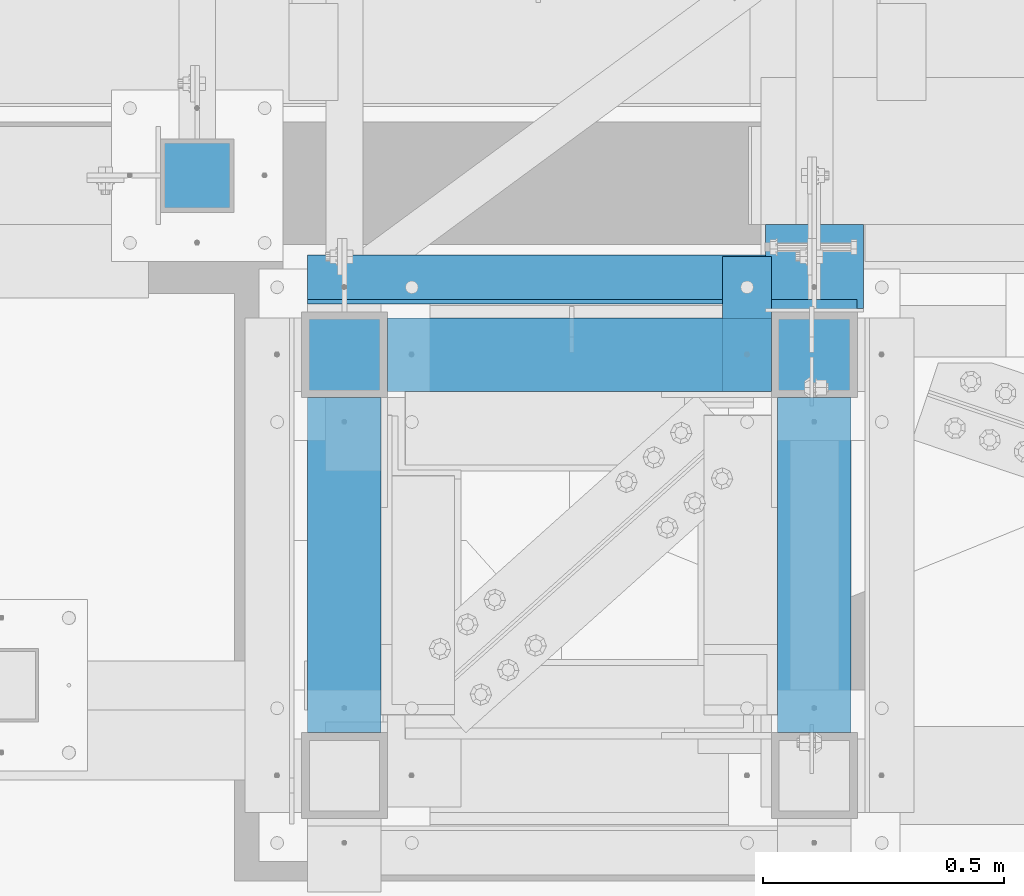
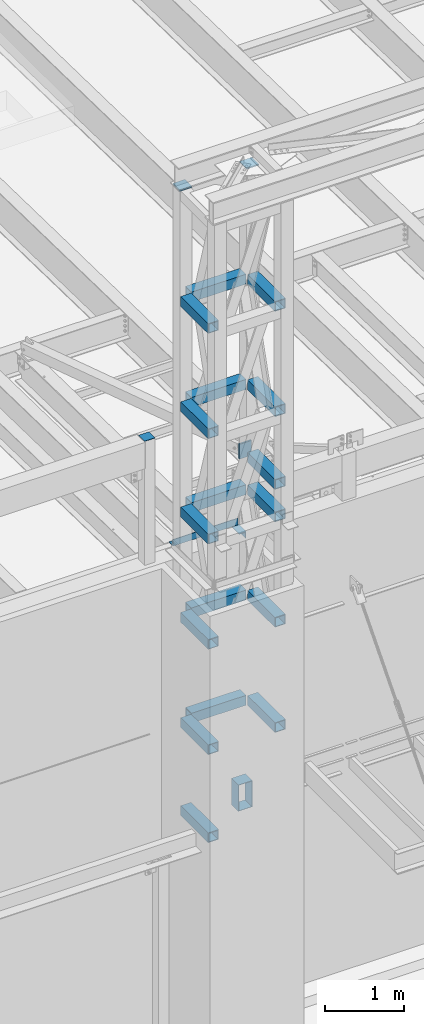
# One storey, part 1200 of 1763: 24 beams, 2 elements without a shape of their own.
"""IFC2X3 building model written with IfcOpenShell, lengths in millimetres."""

from ifc_helpers import new_model, si_unit, frame, origin_with_axes, place, context, subcontext, project, spatial, faceted_brep, material, type_object, element, aggregate, save


model = new_model("IFC2X3")

# Units and contexts
model_context = context("Model", 3, precision=1e-05, world=origin_with_axes())
body_context = subcontext(model_context, "Body", "Model", "MODEL_VIEW")
ifc_project = project(units=[si_unit("LENGTHUNIT", "METRE", prefix="MILLI"), si_unit("AREAUNIT", "SQUARE_METRE"), si_unit("VOLUMEUNIT", "CUBIC_METRE"), si_unit("MASSUNIT", "GRAM", prefix="KILO"), si_unit("TIMEUNIT", "SECOND"), si_unit("PLANEANGLEUNIT", "RADIAN"), si_unit("SOLIDANGLEUNIT", "STERADIAN"), si_unit("THERMODYNAMICTEMPERATUREUNIT", "DEGREE_CELSIUS"), si_unit("LUMINOUSINTENSITYUNIT", "LUMEN")], contexts=[model_context])

# Site, building, storey
site_placement = place(None, origin_with_axes())
site = spatial("IfcSite", under=ifc_project, at=site_placement, CompositionType="ELEMENT")
building_placement = place(site_placement, origin_with_axes())
building = spatial("IfcBuilding", under=site, at=building_placement, Name="Undefined", CompositionType="ELEMENT")
storey_placement = place(building_placement, origin_with_axes())
storey = spatial("IfcBuildingStorey", under=building, at=storey_placement, Name="Undefined", CompositionType="ELEMENT", Elevation=0.0)

# Assembly, beams
assembly_1_placement = place(storey_placement, origin_with_axes())
assembly_1 = element("IfcElementAssembly", 1, at=assembly_1_placement, inside=storey, Name="FRAME", AssemblyPlace="NOTDEFINED", PredefinedType="RIGID_FRAME")
ifc_material_1 = material()
beam_type_1 = type_object("IfcBeamType", Name="HSS6X6X3/8", PredefinedType="NOTDEFINED")
beam_1_placement = place(assembly_1_placement, frame((-63210.5025951483, -15452.7272155183, 14001.7707184703), z_axis=(0.0, 0.0, 1.0), x_axis=(0.0, 1.0, 0.0)))
beam_1 = element("IfcBeam", 2, at=beam_1_placement, type_object=beam_type_1, material=ifc_material_1, Name="BEAM", ObjectType="HSS6X6X3/8", context=body_context, shape_type="Brep", body=[
    faceted_brep([(88.8999008650717, 66.6749999997191, -66.6749999999993), (88.8999007322054, -66.6750000002794, -66.6749999999993), (784.224900732206, -66.6750000025058, -66.6749999999993), (784.224900865072, 66.6749999974927, -66.6749999999993), (88.8999007322054, -66.6750000002794, 66.6749999999993), (784.224900732206, -66.6750000025058, 66.6749999999993), (88.8999008650717, 66.6749999997191, 66.6749999999993), (784.224900865072, 66.6749999974927, 66.6749999999993), (88.8999008745614, 76.1999999997206, -76.2000000000007), (88.8999008745614, 76.1999999997206, 76.2000000000007), (784.224900874562, 76.1999999974942, 76.2000000000007), (784.224900874562, 76.1999999974942, -76.2000000000007), (88.8999007227158, -76.2000000002809, 76.2000000000007), (784.224900722716, -76.2000000025073, 76.2000000000007), (88.8999007227158, -76.2000000002809, -76.2000000000007), (784.224900722716, -76.2000000025073, -76.2000000000007)], [[[0, 1, 2, 3]], [[1, 4, 5, 2]], [[4, 6, 7, 5]], [[6, 0, 3, 7]], [[8, 9, 10, 11]], [[9, 12, 13, 10]], [[12, 14, 15, 13]], [[14, 8, 11, 15]], [[13, 15, 11, 10], [5, 7, 3, 2]], [[14, 12, 9, 8], [6, 4, 1, 0]]]),
])
beam_2_placement = place(assembly_1_placement, frame((-64185.2275957006, -14579.6023151462, 10248.70156), z_axis=(0.0, 0.0, 1.0), x_axis=(0.99999999999718, 2.37500000002911e-06, 0.0)))
beam_2 = element("IfcBeam", 3, at=beam_2_placement, type_object=beam_type_1, material=ifc_material_1, Name="BEAM", ObjectType="HSS6X6X3/8", context=body_context, shape_type="Brep", body=[
    faceted_brep([(88.8999999999996, 66.6750000000029, -66.6749999999993), (88.8996463353687, -66.6749999999556, -66.6749999999993), (885.824841654605, -66.6750000000393, -66.6749999999993), (885.825158360378, 66.6749999998519, -66.6749999999993), (88.8996463353687, -66.6749999999556, 66.6749999999993), (885.824841654605, -66.6750000000393, 66.6749999999993), (88.8999999999996, 66.6750000000029, 66.6749999999993), (885.825158360378, 66.6749999998519, 66.6749999999993), (88.8999999999996, 76.1999999999971, -76.2000000000007), (88.8999999999996, 76.1999999999971, 76.2000000000007), (885.825180982218, 76.1999999998425, 76.2000000000007), (885.825180982218, 76.1999999998425, -76.2000000000007), (88.8996237135289, -76.1999999999498, 76.2000000000007), (885.824819032772, -76.2000000000335, 76.2000000000007), (88.8996237135289, -76.1999999999498, -76.2000000000007), (885.824819032772, -76.2000000000335, -76.2000000000007)], [[[0, 1, 2, 3]], [[1, 4, 5, 2]], [[4, 6, 7, 5]], [[6, 0, 3, 7]], [[8, 9, 10, 11]], [[9, 12, 13, 10]], [[12, 14, 15, 13]], [[14, 8, 11, 15]], [[13, 15, 11, 10], [5, 7, 3, 2]], [[14, 12, 9, 8], [6, 4, 1, 0]]]),
])
beam_3_placement = place(assembly_1_placement, frame((-63210.5025951483, -15452.7272159449, 10248.70156), z_axis=(0.0, 0.0, 1.0), x_axis=(0.0, 1.0, 0.0)))
beam_3 = element("IfcBeam", 4, at=beam_3_placement, type_object=beam_type_1, material=ifc_material_1, Name="BEAM", ObjectType="HSS6X6X3/8", context=body_context, shape_type="Brep", body=[
    faceted_brep([(88.8999008650717, 66.6749999997191, -66.6749999999993), (88.8999007322054, -66.6750000002794, -66.6749999999993), (784.224900732206, -66.6750000025058, -66.6749999999993), (784.224900865072, 66.6749999974927, -66.6749999999993), (88.8999007322054, -66.6750000002794, 66.6749999999993), (784.224900732206, -66.6750000025058, 66.6749999999993), (88.8999008650717, 66.6749999997191, 66.6749999999993), (784.224900865072, 66.6749999974927, 66.6749999999993), (88.8999008745614, 76.1999999997206, -76.2000000000007), (88.8999008745614, 76.1999999997206, 76.2000000000007), (784.224900874562, 76.1999999974942, 76.2000000000007), (784.224900874562, 76.1999999974942, -76.2000000000007), (88.8999007227158, -76.2000000002809, 76.2000000000007), (784.224900722716, -76.2000000025073, 76.2000000000007), (88.8999007227158, -76.2000000002809, -76.2000000000007), (784.224900722716, -76.2000000025073, -76.2000000000007)], [[[0, 1, 2, 3]], [[1, 4, 5, 2]], [[4, 6, 7, 5]], [[6, 0, 3, 7]], [[8, 9, 10, 11]], [[9, 12, 13, 10]], [[12, 14, 15, 13]], [[14, 8, 11, 15]], [[13, 15, 11, 10], [5, 7, 3, 2]], [[14, 12, 9, 8], [6, 4, 1, 0]]]),
])
beam_4_placement = place(assembly_1_placement, frame((-64185.2275951483, -15452.7272100983, 10248.70156), z_axis=(0.0, 0.0, 1.0), x_axis=(0.0, 1.0, 0.0)))
beam_4 = element("IfcBeam", 5, at=beam_4_placement, type_object=beam_type_1, material=ifc_material_1, Name="BEAM", ObjectType="HSS6X6X3/8", context=body_context, shape_type="Brep", body=[
    faceted_brep([(88.8999008650717, 66.6749999997191, -66.6749999999993), (88.8999007322054, -66.6750000002794, -66.6749999999993), (784.224900732206, -66.6750000025058, -66.6749999999993), (784.224900865072, 66.6749999974927, -66.6749999999993), (88.8999007322054, -66.6750000002794, 66.6749999999993), (784.224900732206, -66.6750000025058, 66.6749999999993), (88.8999008650717, 66.6749999997191, 66.6749999999993), (784.224900865072, 66.6749999974927, 66.6749999999993), (88.8999008745614, 76.1999999997206, -76.2000000000007), (88.8999008745614, 76.1999999997206, 76.2000000000007), (784.224900874562, 76.1999999974942, 76.2000000000007), (784.224900874562, 76.1999999974942, -76.2000000000007), (88.8999007227158, -76.2000000002809, 76.2000000000007), (784.224900722716, -76.2000000025073, 76.2000000000007), (88.8999007227158, -76.2000000002809, -76.2000000000007), (784.224900722716, -76.2000000025073, -76.2000000000007)], [[[0, 1, 2, 3]], [[1, 4, 5, 2]], [[4, 6, 7, 5]], [[6, 0, 3, 7]], [[8, 9, 10, 11]], [[9, 12, 13, 10]], [[12, 14, 15, 13]], [[14, 8, 11, 15]], [[13, 15, 11, 10], [5, 7, 3, 2]], [[14, 12, 9, 8], [6, 4, 1, 0]]]),
])
beam_5_placement = place(assembly_1_placement, frame((-64185.2275957006, -14579.6023151462, 11873.706248), z_axis=(0.0, 0.0, 1.0), x_axis=(0.99999999999718, 2.37500000002911e-06, 0.0)))
beam_5 = element("IfcBeam", 6, at=beam_5_placement, type_object=beam_type_1, material=ifc_material_1, Name="BEAM", ObjectType="HSS6X6X3/8", context=body_context, shape_type="Brep", body=[
    faceted_brep([(88.8999999999996, 66.6750000000029, -66.6749999999993), (88.8996463353687, -66.6749999999556, -66.6749999999993), (885.824841654605, -66.6750000000393, -66.6749999999993), (885.825158360378, 66.6749999998519, -66.6749999999993), (88.8996463353687, -66.6749999999556, 66.6749999999993), (885.824841654605, -66.6750000000393, 66.6749999999993), (88.8999999999996, 66.6750000000029, 66.6749999999993), (885.825158360378, 66.6749999998519, 66.6749999999993), (88.8999999999996, 76.1999999999971, -76.2000000000007), (88.8999999999996, 76.1999999999971, 76.2000000000007), (885.825180982218, 76.1999999998425, 76.2000000000007), (885.825180982218, 76.1999999998425, -76.2000000000007), (88.8996237135289, -76.1999999999498, 76.2000000000007), (885.824819032772, -76.2000000000335, 76.2000000000007), (88.8996237135289, -76.1999999999498, -76.2000000000007), (885.824819032772, -76.2000000000335, -76.2000000000007)], [[[0, 1, 2, 3]], [[1, 4, 5, 2]], [[4, 6, 7, 5]], [[6, 0, 3, 7]], [[8, 9, 10, 11]], [[9, 12, 13, 10]], [[12, 14, 15, 13]], [[14, 8, 11, 15]], [[13, 15, 11, 10], [5, 7, 3, 2]], [[14, 12, 9, 8], [6, 4, 1, 0]]]),
])
beam_6_placement = place(assembly_1_placement, frame((-63210.5025951483, -15452.7272159449, 11873.706248), z_axis=(0.0, 0.0, 1.0), x_axis=(0.0, 1.0, 0.0)))
beam_6 = element("IfcBeam", 7, at=beam_6_placement, type_object=beam_type_1, material=ifc_material_1, Name="BEAM", ObjectType="HSS6X6X3/8", context=body_context, shape_type="Brep", body=[
    faceted_brep([(88.8999008650717, 66.6749999997191, -66.6749999999993), (88.8999007322054, -66.6750000002794, -66.6749999999993), (784.224900732206, -66.6750000025058, -66.6749999999993), (784.224900865072, 66.6749999974927, -66.6749999999993), (88.8999007322054, -66.6750000002794, 66.6749999999993), (784.224900732206, -66.6750000025058, 66.6749999999993), (88.8999008650717, 66.6749999997191, 66.6749999999993), (784.224900865072, 66.6749999974927, 66.6749999999993), (88.8999008745614, 76.1999999997206, -76.2000000000007), (88.8999008745614, 76.1999999997206, 76.2000000000007), (784.224900874562, 76.1999999974942, 76.2000000000007), (784.224900874562, 76.1999999974942, -76.2000000000007), (88.8999007227158, -76.2000000002809, 76.2000000000007), (784.224900722716, -76.2000000025073, 76.2000000000007), (88.8999007227158, -76.2000000002809, -76.2000000000007), (784.224900722716, -76.2000000025073, -76.2000000000007)], [[[0, 1, 2, 3]], [[1, 4, 5, 2]], [[4, 6, 7, 5]], [[6, 0, 3, 7]], [[8, 9, 10, 11]], [[9, 12, 13, 10]], [[12, 14, 15, 13]], [[14, 8, 11, 15]], [[13, 15, 11, 10], [5, 7, 3, 2]], [[14, 12, 9, 8], [6, 4, 1, 0]]]),
])
beam_7_placement = place(assembly_1_placement, frame((-64185.2275951483, -15452.7272100983, 11873.706248), z_axis=(0.0, 0.0, 1.0), x_axis=(0.0, 1.0, 0.0)))
beam_7 = element("IfcBeam", 8, at=beam_7_placement, type_object=beam_type_1, material=ifc_material_1, Name="BEAM", ObjectType="HSS6X6X3/8", context=body_context, shape_type="Brep", body=[
    faceted_brep([(88.8999008650717, 66.6749999997191, -66.6749999999993), (88.8999007322054, -66.6750000002794, -66.6749999999993), (784.224900732206, -66.6750000025058, -66.6749999999993), (784.224900865072, 66.6749999974927, -66.6749999999993), (88.8999007322054, -66.6750000002794, 66.6749999999993), (784.224900732206, -66.6750000025058, 66.6749999999993), (88.8999008650717, 66.6749999997191, 66.6749999999993), (784.224900865072, 66.6749999974927, 66.6749999999993), (88.8999008745614, 76.1999999997206, -76.2000000000007), (88.8999008745614, 76.1999999997206, 76.2000000000007), (784.224900874562, 76.1999999974942, 76.2000000000007), (784.224900874562, 76.1999999974942, -76.2000000000007), (88.8999007227158, -76.2000000002809, 76.2000000000007), (784.224900722716, -76.2000000025073, 76.2000000000007), (88.8999007227158, -76.2000000002809, -76.2000000000007), (784.224900722716, -76.2000000025073, -76.2000000000007)], [[[0, 1, 2, 3]], [[1, 4, 5, 2]], [[4, 6, 7, 5]], [[6, 0, 3, 7]], [[8, 9, 10, 11]], [[9, 12, 13, 10]], [[12, 14, 15, 13]], [[14, 8, 11, 15]], [[13, 15, 11, 10], [5, 7, 3, 2]], [[14, 12, 9, 8], [6, 4, 1, 0]]]),
])
beam_8_placement = place(assembly_1_placement, frame((-64185.2275957006, -14579.6023151462, 13498.710936), z_axis=(0.0, 0.0, 1.0), x_axis=(0.99999999999718, 2.37500000002911e-06, 0.0)))
beam_8 = element("IfcBeam", 9, at=beam_8_placement, type_object=beam_type_1, material=ifc_material_1, Name="BEAM", ObjectType="HSS6X6X3/8", context=body_context, shape_type="Brep", body=[
    faceted_brep([(88.8999999999996, 66.6750000000029, -66.6749999999993), (88.8996463353687, -66.6749999999556, -66.6749999999993), (885.824841654605, -66.6750000000393, -66.6749999999993), (885.825158360378, 66.6749999998519, -66.6749999999993), (88.8996463353687, -66.6749999999556, 66.6749999999993), (885.824841654605, -66.6750000000393, 66.6749999999993), (88.8999999999996, 66.6750000000029, 66.6749999999993), (885.825158360378, 66.6749999998519, 66.6749999999993), (88.8999999999996, 76.1999999999971, -76.2000000000007), (88.8999999999996, 76.1999999999971, 76.2000000000007), (885.825180982218, 76.1999999998425, 76.2000000000007), (885.825180982218, 76.1999999998425, -76.2000000000007), (88.8996237135289, -76.1999999999498, 76.2000000000007), (885.824819032772, -76.2000000000335, 76.2000000000007), (88.8996237135289, -76.1999999999498, -76.2000000000007), (885.824819032772, -76.2000000000335, -76.2000000000007)], [[[0, 1, 2, 3]], [[1, 4, 5, 2]], [[4, 6, 7, 5]], [[6, 0, 3, 7]], [[8, 9, 10, 11]], [[9, 12, 13, 10]], [[12, 14, 15, 13]], [[14, 8, 11, 15]], [[13, 15, 11, 10], [5, 7, 3, 2]], [[14, 12, 9, 8], [6, 4, 1, 0]]]),
])
beam_9_placement = place(assembly_1_placement, frame((-63210.5025951483, -15452.7272159449, 13498.710936), z_axis=(0.0, 0.0, 1.0), x_axis=(0.0, 1.0, 0.0)))
beam_9 = element("IfcBeam", 10, at=beam_9_placement, type_object=beam_type_1, material=ifc_material_1, Name="BEAM", ObjectType="HSS6X6X3/8", context=body_context, shape_type="Brep", body=[
    faceted_brep([(88.8999008650717, 66.6749999997191, -66.6749999999993), (88.8999007322054, -66.6750000002794, -66.6749999999993), (784.224900732206, -66.6750000025058, -66.6749999999993), (784.224900865072, 66.6749999974927, -66.6749999999993), (88.8999007322054, -66.6750000002794, 66.6749999999993), (784.224900732206, -66.6750000025058, 66.6749999999993), (88.8999008650717, 66.6749999997191, 66.6749999999993), (784.224900865072, 66.6749999974927, 66.6749999999993), (88.8999008745614, 76.1999999997206, -76.2000000000007), (88.8999008745614, 76.1999999997206, 76.2000000000007), (784.224900874562, 76.1999999974942, 76.2000000000007), (784.224900874562, 76.1999999974942, -76.2000000000007), (88.8999007227158, -76.2000000002809, 76.2000000000007), (784.224900722716, -76.2000000025073, 76.2000000000007), (88.8999007227158, -76.2000000002809, -76.2000000000007), (784.224900722716, -76.2000000025073, -76.2000000000007)], [[[0, 1, 2, 3]], [[1, 4, 5, 2]], [[4, 6, 7, 5]], [[6, 0, 3, 7]], [[8, 9, 10, 11]], [[9, 12, 13, 10]], [[12, 14, 15, 13]], [[14, 8, 11, 15]], [[13, 15, 11, 10], [5, 7, 3, 2]], [[14, 12, 9, 8], [6, 4, 1, 0]]]),
])
beam_10_placement = place(assembly_1_placement, frame((-64185.2275951483, -15452.7272100983, 13498.710936), z_axis=(0.0, 0.0, 1.0), x_axis=(0.0, 1.0, 0.0)))
beam_10 = element("IfcBeam", 11, at=beam_10_placement, type_object=beam_type_1, material=ifc_material_1, Name="BEAM", ObjectType="HSS6X6X3/8", context=body_context, shape_type="Brep", body=[
    faceted_brep([(88.8999008650717, 66.6749999997191, -66.6749999999993), (88.8999007322054, -66.6750000002794, -66.6749999999993), (784.224900732206, -66.6750000025058, -66.6749999999993), (784.224900865072, 66.6749999974927, -66.6749999999993), (88.8999007322054, -66.6750000002794, 66.6749999999993), (784.224900732206, -66.6750000025058, 66.6749999999993), (88.8999008650717, 66.6749999997191, 66.6749999999993), (784.224900865072, 66.6749999974927, 66.6749999999993), (88.8999008745614, 76.1999999997206, -76.2000000000007), (88.8999008745614, 76.1999999997206, 76.2000000000007), (784.224900874562, 76.1999999974942, 76.2000000000007), (784.224900874562, 76.1999999974942, -76.2000000000007), (88.8999007227158, -76.2000000002809, 76.2000000000007), (784.224900722716, -76.2000000025073, 76.2000000000007), (88.8999007227158, -76.2000000002809, -76.2000000000007), (784.224900722716, -76.2000000025073, -76.2000000000007)], [[[0, 1, 2, 3]], [[1, 4, 5, 2]], [[4, 6, 7, 5]], [[6, 0, 3, 7]], [[8, 9, 10, 11]], [[9, 12, 13, 10]], [[12, 14, 15, 13]], [[14, 8, 11, 15]], [[13, 15, 11, 10], [5, 7, 3, 2]], [[14, 12, 9, 8], [6, 4, 1, 0]]]),
])
beam_11_placement = place(assembly_1_placement, frame((-64185.2275957006, -14579.6023151462, 15123.715624), z_axis=(0.0, 0.0, 1.0), x_axis=(0.99999999999718, 2.37500000002911e-06, 0.0)))
beam_11 = element("IfcBeam", 12, at=beam_11_placement, type_object=beam_type_1, material=ifc_material_1, Name="BEAM", ObjectType="HSS6X6X3/8", context=body_context, shape_type="Brep", body=[
    faceted_brep([(88.8999999999996, 66.6750000000029, -66.6749999999993), (88.8996463353687, -66.6749999999556, -66.6749999999993), (885.824841654605, -66.6750000000393, -66.6749999999993), (885.825158360378, 66.6749999998519, -66.6749999999993), (88.8996463353687, -66.6749999999556, 66.6749999999993), (885.824841654605, -66.6750000000393, 66.6749999999993), (88.8999999999996, 66.6750000000029, 66.6749999999993), (885.825158360378, 66.6749999998519, 66.6749999999993), (88.8999999999996, 76.1999999999971, -76.2000000000007), (88.8999999999996, 76.1999999999971, 76.2000000000007), (885.825180982218, 76.1999999998425, 76.2000000000007), (885.825180982218, 76.1999999998425, -76.2000000000007), (88.8996237135289, -76.1999999999498, 76.2000000000007), (885.824819032772, -76.2000000000335, 76.2000000000007), (88.8996237135289, -76.1999999999498, -76.2000000000007), (885.824819032772, -76.2000000000335, -76.2000000000007)], [[[0, 1, 2, 3]], [[1, 4, 5, 2]], [[4, 6, 7, 5]], [[6, 0, 3, 7]], [[8, 9, 10, 11]], [[9, 12, 13, 10]], [[12, 14, 15, 13]], [[14, 8, 11, 15]], [[13, 15, 11, 10], [5, 7, 3, 2]], [[14, 12, 9, 8], [6, 4, 1, 0]]]),
])
beam_12_placement = place(assembly_1_placement, frame((-63210.5025951483, -15452.7272159449, 15123.715624), z_axis=(0.0, 0.0, 1.0), x_axis=(0.0, 1.0, 0.0)))
beam_12 = element("IfcBeam", 13, at=beam_12_placement, type_object=beam_type_1, material=ifc_material_1, Name="BEAM", ObjectType="HSS6X6X3/8", context=body_context, shape_type="Brep", body=[
    faceted_brep([(88.8999008650717, 66.6749999997191, -66.6749999999993), (88.8999007322054, -66.6750000002794, -66.6749999999993), (784.224900732206, -66.6750000025058, -66.6749999999993), (784.224900865072, 66.6749999974927, -66.6749999999993), (88.8999007322054, -66.6750000002794, 66.6749999999993), (784.224900732206, -66.6750000025058, 66.6749999999993), (88.8999008650717, 66.6749999997191, 66.6749999999993), (784.224900865072, 66.6749999974927, 66.6749999999993), (88.8999008745614, 76.1999999997206, -76.2000000000007), (88.8999008745614, 76.1999999997206, 76.2000000000007), (784.224900874562, 76.1999999974942, 76.2000000000007), (784.224900874562, 76.1999999974942, -76.2000000000007), (88.8999007227158, -76.2000000002809, 76.2000000000007), (784.224900722716, -76.2000000025073, 76.2000000000007), (88.8999007227158, -76.2000000002809, -76.2000000000007), (784.224900722716, -76.2000000025073, -76.2000000000007)], [[[0, 1, 2, 3]], [[1, 4, 5, 2]], [[4, 6, 7, 5]], [[6, 0, 3, 7]], [[8, 9, 10, 11]], [[9, 12, 13, 10]], [[12, 14, 15, 13]], [[14, 8, 11, 15]], [[13, 15, 11, 10], [5, 7, 3, 2]], [[14, 12, 9, 8], [6, 4, 1, 0]]]),
])
beam_13_placement = place(assembly_1_placement, frame((-64185.2275951483, -15452.7272100983, 15123.715624), z_axis=(0.0, 0.0, 1.0), x_axis=(0.0, 1.0, 0.0)))
beam_13 = element("IfcBeam", 14, at=beam_13_placement, type_object=beam_type_1, material=ifc_material_1, Name="BEAM", ObjectType="HSS6X6X3/8", context=body_context, shape_type="Brep", body=[
    faceted_brep([(88.8999008650717, 66.6749999997191, -66.6749999999993), (88.8999007322054, -66.6750000002794, -66.6749999999993), (784.224900732206, -66.6750000025058, -66.6749999999993), (784.224900865072, 66.6749999974927, -66.6749999999993), (88.8999007322054, -66.6750000002794, 66.6749999999993), (784.224900732206, -66.6750000025058, 66.6749999999993), (88.8999008650717, 66.6749999997191, 66.6749999999993), (784.224900865072, 66.6749999974927, 66.6749999999993), (88.8999008745614, 76.1999999997206, -76.2000000000007), (88.8999008745614, 76.1999999997206, 76.2000000000007), (784.224900874562, 76.1999999974942, 76.2000000000007), (784.224900874562, 76.1999999974942, -76.2000000000007), (88.8999007227158, -76.2000000002809, 76.2000000000007), (784.224900722716, -76.2000000025073, 76.2000000000007), (88.8999007227158, -76.2000000002809, -76.2000000000007), (784.224900722716, -76.2000000025073, -76.2000000000007)], [[[0, 1, 2, 3]], [[1, 4, 5, 2]], [[4, 6, 7, 5]], [[6, 0, 3, 7]], [[8, 9, 10, 11]], [[9, 12, 13, 10]], [[12, 14, 15, 13]], [[14, 8, 11, 15]], [[13, 15, 11, 10], [5, 7, 3, 2]], [[14, 12, 9, 8], [6, 4, 1, 0]]]),
])
beam_14_placement = place(assembly_1_placement, frame((-64185.2275957006, -14579.6023151462, 16748.720312), z_axis=(0.0, 0.0, 1.0), x_axis=(0.99999999999718, 2.37500000002911e-06, 0.0)))
beam_14 = element("IfcBeam", 15, at=beam_14_placement, type_object=beam_type_1, material=ifc_material_1, Name="BEAM", ObjectType="HSS6X6X3/8", context=body_context, shape_type="Brep", body=[
    faceted_brep([(88.8999999999996, 66.6750000000029, -66.6749999999993), (88.8996463353687, -66.6749999999556, -66.6749999999993), (885.824841654605, -66.6750000000393, -66.6749999999993), (885.825158360378, 66.6749999998519, -66.6749999999993), (88.8996463353687, -66.6749999999556, 66.6749999999993), (885.824841654605, -66.6750000000393, 66.6749999999993), (88.8999999999996, 66.6750000000029, 66.6749999999993), (885.825158360378, 66.6749999998519, 66.6749999999993), (88.8999999999996, 76.1999999999971, -76.2000000000007), (88.8999999999996, 76.1999999999971, 76.2000000000007), (885.825180982218, 76.1999999998425, 76.2000000000007), (885.825180982218, 76.1999999998425, -76.2000000000007), (88.8996237135289, -76.1999999999498, 76.2000000000007), (885.824819032772, -76.2000000000335, 76.2000000000007), (88.8996237135289, -76.1999999999498, -76.2000000000007), (885.824819032772, -76.2000000000335, -76.2000000000007)], [[[0, 1, 2, 3]], [[1, 4, 5, 2]], [[4, 6, 7, 5]], [[6, 0, 3, 7]], [[8, 9, 10, 11]], [[9, 12, 13, 10]], [[12, 14, 15, 13]], [[14, 8, 11, 15]], [[13, 15, 11, 10], [5, 7, 3, 2]], [[14, 12, 9, 8], [6, 4, 1, 0]]]),
])
beam_15_placement = place(assembly_1_placement, frame((-63210.5025951483, -15452.7272159449, 16748.720312), z_axis=(0.0, 0.0, 1.0), x_axis=(0.0, 1.0, 0.0)))
beam_15 = element("IfcBeam", 16, at=beam_15_placement, type_object=beam_type_1, material=ifc_material_1, Name="BEAM", ObjectType="HSS6X6X3/8", context=body_context, shape_type="Brep", body=[
    faceted_brep([(88.8999008650717, 66.6749999997191, -66.6749999999993), (88.8999007322054, -66.6750000002794, -66.6749999999993), (784.224900732206, -66.6750000025058, -66.6749999999993), (784.224900865072, 66.6749999974927, -66.6749999999993), (88.8999007322054, -66.6750000002794, 66.6749999999993), (784.224900732206, -66.6750000025058, 66.6749999999993), (88.8999008650717, 66.6749999997191, 66.6749999999993), (784.224900865072, 66.6749999974927, 66.6749999999993), (88.8999008745614, 76.1999999997206, -76.2000000000007), (88.8999008745614, 76.1999999997206, 76.2000000000007), (784.224900874562, 76.1999999974942, 76.2000000000007), (784.224900874562, 76.1999999974942, -76.2000000000007), (88.8999007227158, -76.2000000002809, 76.2000000000007), (784.224900722716, -76.2000000025073, 76.2000000000007), (88.8999007227158, -76.2000000002809, -76.2000000000007), (784.224900722716, -76.2000000025073, -76.2000000000007)], [[[0, 1, 2, 3]], [[1, 4, 5, 2]], [[4, 6, 7, 5]], [[6, 0, 3, 7]], [[8, 9, 10, 11]], [[9, 12, 13, 10]], [[12, 14, 15, 13]], [[14, 8, 11, 15]], [[13, 15, 11, 10], [5, 7, 3, 2]], [[14, 12, 9, 8], [6, 4, 1, 0]]]),
])
beam_16_placement = place(assembly_1_placement, frame((-64185.2275951483, -15452.7272100983, 16748.720312), z_axis=(0.0, 0.0, 1.0), x_axis=(0.0, 1.0, 0.0)))
beam_16 = element("IfcBeam", 17, at=beam_16_placement, type_object=beam_type_1, material=ifc_material_1, Name="BEAM", ObjectType="HSS6X6X3/8", context=body_context, shape_type="Brep", body=[
    faceted_brep([(88.8999008650717, 66.6749999997191, -66.6749999999993), (88.8999007322054, -66.6750000002794, -66.6749999999993), (784.224900732206, -66.6750000025058, -66.6749999999993), (784.224900865072, 66.6749999974927, -66.6749999999993), (88.8999007322054, -66.6750000002794, 66.6749999999993), (784.224900732206, -66.6750000025058, 66.6749999999993), (88.8999008650717, 66.6749999997191, 66.6749999999993), (784.224900865072, 66.6749999974927, 66.6749999999993), (88.8999008745614, 76.1999999997206, -76.2000000000007), (88.8999008745614, 76.1999999997206, 76.2000000000007), (784.224900874562, 76.1999999974942, 76.2000000000007), (784.224900874562, 76.1999999974942, -76.2000000000007), (88.8999007227158, -76.2000000002809, 76.2000000000007), (784.224900722716, -76.2000000025073, 76.2000000000007), (88.8999007227158, -76.2000000002809, -76.2000000000007), (784.224900722716, -76.2000000025073, -76.2000000000007)], [[[0, 1, 2, 3]], [[1, 4, 5, 2]], [[4, 6, 7, 5]], [[6, 0, 3, 7]], [[8, 9, 10, 11]], [[9, 12, 13, 10]], [[12, 14, 15, 13]], [[14, 8, 11, 15]], [[13, 15, 11, 10], [5, 7, 3, 2]], [[14, 12, 9, 8], [6, 4, 1, 0]]]),
])
beam_17_placement = place(assembly_1_placement, frame((-64185.2275957006, -15452.7273151462, 8890.0), z_axis=(0.0, 0.0, 1.0), x_axis=(0.0, 1.0, 0.0)))
beam_17 = element("IfcBeam", 18, at=beam_17_placement, type_object=beam_type_1, material=ifc_material_1, Name="BEAM", ObjectType="HSS6X6X3/8", context=body_context, shape_type="Brep", body=[
    faceted_brep([(88.8999999999996, 66.6750000000029, -66.6749999999993), (88.8999999999996, -66.6750000000029, -66.6749999999993), (784.225, -66.6750000000029, -66.6749999999993), (784.225, 66.6750000000029, -66.6749999999993), (88.8999999999996, -66.6750000000029, 66.6749999999993), (784.225, -66.6750000000029, 66.6749999999993), (88.8999999999996, 66.6750000000029, 66.6749999999993), (784.225, 66.6750000000029, 66.6749999999993), (88.8999999999996, 76.1999999999971, -76.2000000000007), (88.8999999999996, 76.1999999999971, 76.2000000000007), (784.225, 76.1999999999971, 76.2000000000007), (784.225, 76.1999999999971, -76.2000000000007), (88.8999999999996, -76.1999999999971, 76.2000000000007), (784.225, -76.1999999999971, 76.2000000000007), (88.8999999999996, -76.1999999999971, -76.2000000000007), (784.225, -76.1999999999971, -76.2000000000007)], [[[0, 1, 2, 3]], [[1, 4, 5, 2]], [[4, 6, 7, 5]], [[6, 0, 3, 7]], [[8, 9, 10, 11]], [[9, 12, 13, 10]], [[12, 14, 15, 13]], [[14, 8, 11, 15]], [[13, 15, 11, 10], [5, 7, 3, 2]], [[14, 12, 9, 8], [6, 4, 1, 0]]]),
])
ifc_material_2 = material(Name="STEEL/A36")
beam_type_2 = type_object("IfcBeamType", PredefinedType="NOTDEFINED")
beam_18_placement = place(assembly_1_placement, frame((-63211.0608225783, -14478.0023133202, 14097.0459704449), z_axis=(1.0, 0.0, 0.0), x_axis=(0.0, 0.0, -1.0)))
beam_18 = element("IfcBeam", 19, at=beam_18_placement, type_object=beam_type_2, material=ifc_material_2, Name="PLATE", context=body_context, shape_type="Brep", body=[
    faceted_brep([(0.0, 12.7000000000007, -88.9000000000015), (0.0, 12.7000000000007, 88.9000000000015), (228.6, 12.7000000000007, 88.9000000000015), (228.6, 12.7000000000007, -88.9000000000015), (0.0, -12.7000000000007, 88.9000000000015), (228.6, -12.7000000000007, 88.9000000000015), (0.0, -12.7000000000007, -88.9000000000015), (228.6, -12.7000000000007, -88.9000000000015)], [[[0, 1, 2, 3]], [[1, 4, 5, 2]], [[4, 6, 7, 5]], [[6, 0, 3, 7]], [[5, 7, 3, 2]], [[6, 4, 1, 0]]]),
])
beam_type_3 = type_object("IfcBeamType", Name="L4X4X3/8", PredefinedType="NOTDEFINED")
beam_19_placement = place(assembly_1_placement, frame((-63350.2025957006, -14655.8023151462, 12801.6221257957), z_axis=(0.0, 0.0, -1.0), x_axis=(0.0, 1.0, 0.0)))
beam_19 = element("IfcBeam", 20, at=beam_19_placement, type_object=beam_type_3, material=ifc_material_2, Name="ANGLE", ObjectType="L4X4X3/8", context=body_context, shape_type="Brep", body=[
    faceted_brep([(-3.63797880709171e-11, 50.8000000000011, -50.8000000000538), (-1.96450855582952e-10, 50.8000000000393, 50.7999999999374), (279.4, 50.8000000000029, 50.7999999999993), (279.4, 50.8000000000029, -50.7999999999993), (0.0, 41.2749999999996, 50.7999999999993), (279.4, 41.2750000000015, 50.7999999999993), (0.0, 41.2749999999996, -41.2750000000015), (279.4, 41.2750000000015, -41.2749999999996), (0.0, -50.7999999999993, -41.2750000000015), (279.4, -50.8000000000029, -41.2749999999996), (2.11002770811319e-10, -50.8000000000357, -50.799999999952), (279.4, -50.8000000000029, -50.7999999999993)], [[[0, 1, 2, 3]], [[1, 4, 5, 2]], [[4, 6, 7, 5]], [[6, 8, 9, 7]], [[8, 10, 11, 9]], [[10, 0, 3, 11]], [[5, 7, 9, 11, 3, 2]], [[10, 8, 6, 4, 1, 0]]]),
])
beam_20_placement = place(assembly_1_placement, frame((-64261.4289752207, -14424.0273151462, 12903.1999999862), z_axis=(0.0, 1.0, 0.0), x_axis=(0.999999999728392, 3.99999966736324e-09, 2.33069999932242e-05)))
beam_20 = element("IfcBeam", 21, at=beam_20_placement, type_object=beam_type_3, material=ifc_material_2, Name="ANGLE", ObjectType="L4X4X3/8", context=body_context, shape_type="Brep", body=[
    faceted_brep([(-3.63797880709171e-11, 50.8000000000011, -50.8000000000538), (-1.96450855582952e-10, 50.8000000000393, 50.7999999999374), (949.325195572463, 50.8000000004577, 50.7999999999993), (949.325195572463, 50.8000000004577, -50.7999999999993), (0.0, 41.2749999999996, 50.7999999999993), (949.325195572485, 41.2750000004526, 50.7999999999993), (0.0, 41.2749999999996, -41.2750000000015), (949.325195572485, 41.2750000004526, -41.2749999999996), (0.0, -50.7999999999993, -41.2750000000015), (949.325195572696, -50.7999999996009, -41.2749999999996), (2.11002770811319e-10, -50.8000000000357, -50.799999999952), (949.325195572696, -50.7999999996009, -50.7999999999993)], [[[0, 1, 2, 3]], [[1, 4, 5, 2]], [[4, 6, 7, 5]], [[6, 8, 9, 7]], [[8, 10, 11, 9]], [[10, 0, 3, 11]], [[5, 7, 9, 11, 3, 2]], [[10, 8, 6, 4, 1, 0]]]),
])
beam_type_4 = type_object("IfcBeamType", Name="HSS16X8X1/4", PredefinedType="NOTDEFINED")
beam_21_placement = place(assembly_1_placement, frame((-63210.5025998741, -14490.7022745338, 8636.0), z_axis=(0.0, 0.0, 1.0), x_axis=(0.0, 1.0, 0.0)))
beam_21 = element("IfcBeam", 22, at=beam_21_placement, type_object=beam_type_4, material=ifc_material_1, Name="BEAM", ObjectType="HSS16X8X1/4", context=body_context, shape_type="Brep", body=[
    faceted_brep([(6.35000009548457, 95.2499999999854, -196.85), (6.3499999048563, -95.2500000000146, -196.85), (180.974693656795, -95.2500000003201, -196.85), (180.97469365679, 95.2499999996799, -196.85), (6.3499999048563, -95.2500000000146, 196.85), (180.974693656795, -95.2500000003201, 196.85), (6.35000009548457, 95.2499999999854, 196.85), (180.97469365679, 95.2499999996799, 196.85), (6.35000010184012, 101.599999999984, -203.200000000001), (6.35000010184012, 101.599999999984, 203.200000000001), (180.974693656788, 101.599999999678, 203.200000000001), (180.974693656788, 101.599999999678, -203.200000000001), (6.34999989850257, -101.600000000013, 203.200000000001), (180.974693656795, -101.600000000326, 203.200000000001), (6.34999989850257, -101.600000000013, -203.200000000001), (180.974693656795, -101.600000000326, -203.200000000001)], [[[0, 1, 2, 3]], [[1, 4, 5, 2]], [[4, 6, 7, 5]], [[6, 0, 3, 7]], [[8, 9, 10, 11]], [[9, 12, 13, 10]], [[12, 14, 15, 13]], [[14, 8, 11, 15]], [[13, 15, 11, 10], [5, 7, 3, 2]], [[14, 12, 9, 8], [6, 4, 1, 0]]]),
])

# Assembly, beam
assembly_2_placement = place(storey_placement, origin_with_axes())
assembly_2 = element("IfcElementAssembly", 23, at=assembly_2_placement, inside=storey, Name="COLUMN", AssemblyPlace="NOTDEFINED", PredefinedType="RIGID_FRAME")
beam_type_5 = type_object("IfcBeamType", PredefinedType="NOTDEFINED")
beam_22_placement = place(assembly_2_placement, frame((-64490.482374092, -14284.3264769908, 14462.125), z_axis=(1.0, 0.0, 0.0), x_axis=(0.0, 1.0, 0.0)))
beam_22 = element("IfcBeam", 24, at=beam_22_placement, type_object=beam_type_5, material=ifc_material_2, Name="PLATE", context=body_context, shape_type="Brep", body=[
    faceted_brep([(0.0, 3.17500000001746, -76.2000000000007), (-1.51339918375015e-09, 3.17499999999927, 76.1999969482422), (152.399990844715, 3.17500000000291, 76.2000000000007), (152.399990844715, 3.17500000000291, -76.2000000000007), (-1.51339918375015e-09, -3.17499999999927, 76.1999969482422), (152.399990844715, -3.17500000000291, 76.2000000000007), (0.0, -3.17500000000291, -76.2000000000007), (152.399990844715, -3.17500000000291, -76.2000000000007)], [[[0, 1, 2, 3]], [[1, 4, 5, 2]], [[4, 6, 7, 5]], [[6, 0, 3, 7]], [[5, 7, 3, 2]], [[6, 4, 1, 0]]]),
])
aggregate(assembly_2, [beam_22])

# Beam
beam_type_6 = type_object("IfcBeamType", PredefinedType="NOTDEFINED")
beam_23_placement = place(assembly_1_placement, frame((-63210.5025957005, -14668.5023151462, 18459.45), z_axis=(1.0, 0.0, 0.0), x_axis=(0.0, 1.0, 0.0)))
beam_23 = element("IfcBeam", 25, at=beam_23_placement, type_object=beam_type_6, material=ifc_material_2, Name="PLATE", context=body_context, shape_type="Brep", body=[
    faceted_brep([(0.0, 9.52500000000146, -88.9000000000015), (0.0, 9.52500000000146, 88.9000000000015), (177.799999999999, 9.52500000000146, 88.9000000000015), (177.799999999999, 9.52500000000146, -88.9000000000015), (0.0, -9.52500000000146, 88.9000000000015), (177.799999999999, -9.52500000000146, 88.9000000000015), (0.0, -9.52500000000146, -88.9000000000015), (177.799999999999, -9.52500000000146, -88.9000000000015)], [[[0, 1, 2, 3]], [[1, 4, 5, 2]], [[4, 6, 7, 5]], [[6, 0, 3, 7]], [[5, 7, 3, 2]], [[6, 4, 1, 0]]]),
])

beam_24_placement = place(assembly_1_placement, frame((-64185.2277910131, -14668.5023151462, 18459.45), z_axis=(1.0, 0.0, 0.0), x_axis=(0.0, 1.0, 0.0)))
beam_24 = element("IfcBeam", 26, at=beam_24_placement, type_object=beam_type_6, material=ifc_material_2, Name="PLATE", context=body_context, shape_type="Brep", body=[
    faceted_brep([(0.0, 9.52500000000146, -88.9000000000015), (0.0, 9.52500000000146, 88.9000000000015), (177.799999999999, 9.52500000000146, 88.9000000000015), (177.799999999999, 9.52500000000146, -88.9000000000015), (0.0, -9.52500000000146, 88.9000000000015), (177.799999999999, -9.52500000000146, 88.9000000000015), (0.0, -9.52500000000146, -88.9000000000015), (177.799999999999, -9.52500000000146, -88.9000000000015)], [[[0, 1, 2, 3]], [[1, 4, 5, 2]], [[4, 6, 7, 5]], [[6, 0, 3, 7]], [[5, 7, 3, 2]], [[6, 4, 1, 0]]]),
])

aggregate(assembly_1, [beam_1, beam_18, beam_2, beam_3, beam_4, beam_5, beam_6, beam_7, beam_8, beam_9, beam_10, beam_11, beam_12, beam_13, beam_14, beam_15, beam_16, beam_19, beam_20, beam_17, beam_21, beam_23, beam_24])

save(model, "model.ifc")
